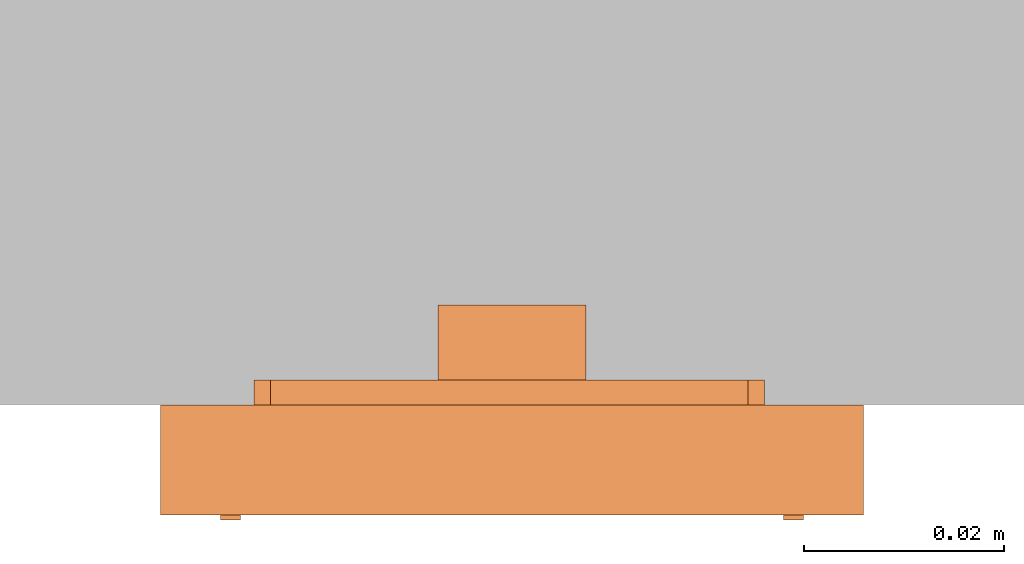
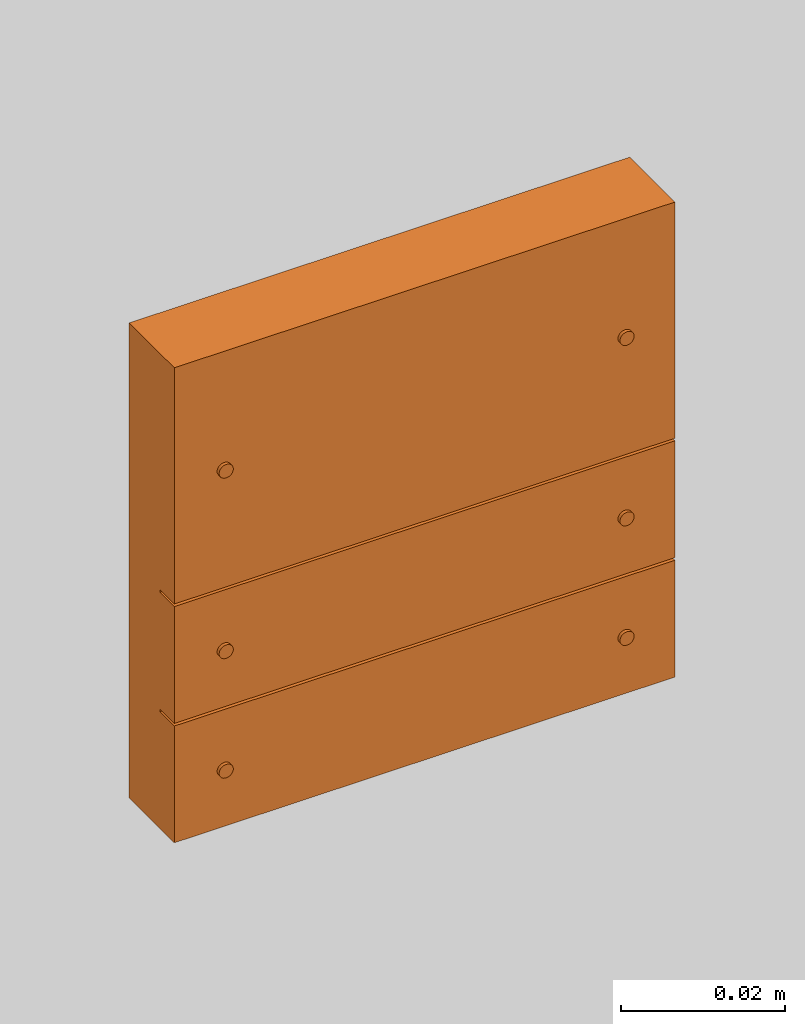
# One storey, part 2 of 2: 1 proxy.
"""IFC2X3 building model written with IfcOpenShell, lengths in metres."""

from ifc_helpers import new_model, entity, si_unit, converted_unit, derived_unit, direction, frame, frame_2d, origin, origin_2d_with_axis, place, context, subcontext, project, spatial, polyline, circle_curve, parameter, trimmed, segment, composite_curve, rectangle, circle, outline, extrude, source, transform, mapped, type_object, type_shapes, element, save


model = new_model("IFC2X3")

# Units and contexts
model_context = context("Model", 3, precision=1e-05, world=origin(), true_north=direction((6.12303176911189e-17, 1.0)))
body_context = subcontext(model_context, "Body", "Model", "MODEL_VIEW")
ifc_project = project(units=[si_unit("LENGTHUNIT", "METRE"), si_unit("AREAUNIT", "SQUARE_METRE"), si_unit("VOLUMEUNIT", "CUBIC_METRE"), converted_unit("PLANEANGLEUNIT", "DEGREE", entity("IfcRatioMeasure", 0.0174532925199433), si_unit("PLANEANGLEUNIT", "RADIAN"), dimensions=[0, 0, 0, 0, 0, 0, 0]), si_unit("MASSUNIT", "GRAM", prefix="KILO"), si_unit("TIMEUNIT", "SECOND"), si_unit("FREQUENCYUNIT", "HERTZ"), si_unit("THERMODYNAMICTEMPERATUREUNIT", "DEGREE_CELSIUS"), derived_unit("THERMALTRANSMITTANCEUNIT", [(si_unit("MASSUNIT", "GRAM", prefix="KILO"), 1), (si_unit("THERMODYNAMICTEMPERATUREUNIT", "KELVIN"), -1), (si_unit("TIMEUNIT", "SECOND"), -3)]), derived_unit("VOLUMETRICFLOWRATEUNIT", [(si_unit("LENGTHUNIT", "METRE"), 3), (si_unit("TIMEUNIT", "SECOND"), -1)]), si_unit("ELECTRICCURRENTUNIT", "AMPERE"), si_unit("ELECTRICVOLTAGEUNIT", "VOLT"), si_unit("POWERUNIT", "WATT"), si_unit("FORCEUNIT", "NEWTON", prefix="KILO"), si_unit("ILLUMINANCEUNIT", "LUX"), si_unit("LUMINOUSFLUXUNIT", "LUMEN"), si_unit("LUMINOUSINTENSITYUNIT", "CANDELA"), derived_unit("USERDEFINED", [(si_unit("MASSUNIT", "GRAM", prefix="KILO"), -1), (si_unit("LENGTHUNIT", "METRE"), -2), (si_unit("TIMEUNIT", "SECOND"), 3), (si_unit("LUMINOUSFLUXUNIT", "LUMEN"), 1)]), derived_unit("LINEARVELOCITYUNIT", [(si_unit("LENGTHUNIT", "METRE"), 1), (si_unit("TIMEUNIT", "SECOND"), -1)]), si_unit("PRESSUREUNIT", "PASCAL"), derived_unit("USERDEFINED", [(si_unit("LENGTHUNIT", "METRE"), -2), (si_unit("MASSUNIT", "GRAM", prefix="KILO"), 1), (si_unit("TIMEUNIT", "SECOND"), -2)])], contexts=[model_context])

# Site, building, storey
site_placement = place(None, origin())
site = spatial("IfcSite", under=ifc_project, at=site_placement, CompositionType="ELEMENT")
building_placement = place(site_placement, origin())
building = spatial("IfcBuilding", under=site, at=building_placement, CompositionType="ELEMENT")
storey_placement = place(building_placement, origin())
storey = spatial("IfcBuildingStorey", under=building, at=storey_placement, Name="Ebene 0", CompositionType="ELEMENT", Elevation=0.0)

# Proxy
building_element_proxy_type = type_object("IfcBuildingElementProxyType", Name="KNX 3 Plus 2f", PredefinedType="NOTDEFINED")
shared_shape = source(origin(), body_context, "Body", "SweptSolid", [
    extrude(circle(Radius=0.001, at=frame_2d((0.0, -4.22994972382185e-18), x_axis=(1.0, 0.0))), frame((0.0281503279999937, -0.0267710735000254, 0.0109999999999981), z_axis=(0.0, 0.0, 1.0), x_axis=(-1.0, 0.0, 0.0)), (0.0, 0.0, 1.0), 0.000500000000000028),
    extrude(circle(Radius=0.001, at=frame_2d((0.0, -4.22994972382185e-18), x_axis=(1.0, 0.0))), frame((-0.0281503279999813, -0.0267710735000254, 0.0109999999999981)), (0.0, 0.0, 1.0), 0.000500000000000028),
    extrude(circle(Radius=0.001, at=frame_2d((0.0, -2.11497486191092e-18), x_axis=(1.0, 0.0))), frame((0.0281503279999938, -0.00902937150002535, 0.0109999999999981), z_axis=(0.0, 0.0, 1.0), x_axis=(-1.0, 0.0, 0.0)), (0.0, 0.0, 1.0), 0.000500000000000028),
    extrude(circle(Radius=0.001, at=frame_2d((0.0, -2.11497486191092e-18), x_axis=(1.0, 0.0))), frame((-0.0281503279999813, -0.00902937150002534, 0.0109999999999981)), (0.0, 0.0, 1.0), 0.000500000000000028),
    extrude(circle(Radius=0.001, at=frame_2d((0.0, -2.11497486191092e-18), x_axis=(1.0, 0.0))), frame((0.0281503279999938, 0.0177710734999747, 0.0109999999999981), z_axis=(0.0, 0.0, 1.0), x_axis=(-1.0, 0.0, 0.0)), (0.0, 0.0, 1.0), 0.000500000000000028),
    extrude(circle(Radius=0.001, at=frame_2d((0.0, -2.11497486191092e-18), x_axis=(1.0, 0.0))), frame((-0.0281503279999812, 0.0177710734999747, 0.0109999999999981)), (0.0, 0.0, 1.0), 0.000500000000000028),
    extrude(outline(polyline([(-0.00737665776090717, -0.00321845649999999), (0.00738192423909283, -0.00321845649999999), (0.00738192423909283, 0.00284013749999998), (0.00654480379664712, 0.00284013749999999), (0.00654480379664711, -0.00245988050000001), (-0.00655007027483279, -0.00245988050000001), (-0.00655007027483277, 0.00283819950000001), (-0.00737665776090717, 0.00283819950000001), (-0.00737665776090717, -0.00321845649999999)])), frame((2.63323911162365e-06, -0.0184309360000254, -0.0100000000000019), z_axis=(0.0, 0.0, 1.0), x_axis=(-1.0, 0.0, 0.0)), (0.0, 0.0, 1.0), 0.0075),
    extrude(outline(composite_curve([segment(polyline([(0.000467124920745127, -0.0238772156111111), (0.0193443469207452, -0.0238772156111111)]), True, "CONTINUOUS"), segment(trimmed(circle_curve(frame_2d((0.0193443469207451, -0.0188772156111111), x_axis=(-1.0, 0.0)), 0.005), [parameter(90.0000000000001)], [parameter(180.0)], True, "PARAMETER"), True, "CONTINUOUS"), segment(polyline([(0.0243443469207451, -0.0188772156111111), (0.0243443469207451, -0.00697722161111111)]), True, "CONTINUOUS"), segment(polyline([(0.0243443469207451, -0.00697722161111111), (0.0259943469207451, -0.00697722161111111)]), True, "CONTINUOUS"), segment(polyline([(0.0259943469207451, -0.00697722161111111), (0.0259943469207451, 0.00697722338888888)]), True, "CONTINUOUS"), segment(polyline([(0.0259943469207451, 0.00697722338888888), (0.0243443469207451, 0.00697722338888888)]), True, "CONTINUOUS"), segment(polyline([(0.0243443469207451, 0.00697722338888888), (0.0243443469207451, 0.0188772173888889)]), True, "CONTINUOUS"), segment(trimmed(circle_curve(frame_2d((0.0193443469207451, 0.0188772173888889), x_axis=(-1.0, 0.0)), 0.005), [parameter(180.0)], [parameter(269.999999999999)], True, "PARAMETER"), True, "CONTINUOUS"), segment(polyline([(0.0193443469207451, 0.0238772173888889), (-0.00794112365266727, 0.0238772173888889)]), True, "CONTINUOUS"), segment(polyline([(-0.00794112365266727, 0.0238772173888889), (-0.0184100970792549, 0.0238772173888889)]), True, "CONTINUOUS"), segment(trimmed(circle_curve(frame_2d((-0.0184100970792549, 0.0188772173888889), x_axis=(-1.0, 0.0)), 0.005), [parameter(269.999999999999)], [parameter(360.0)], True, "PARAMETER"), True, "CONTINUOUS"), segment(polyline([(-0.0234100970792549, 0.0188772173888889), (-0.0234100970792549, 0.00697722338888889)]), True, "CONTINUOUS"), segment(polyline([(-0.0234100970792549, 0.00697722338888889), (-0.0250600970792549, 0.00697722338888889)]), True, "CONTINUOUS"), segment(polyline([(-0.0250600970792549, 0.00697722338888889), (-0.0250600970792549, -0.0069772216111111)]), True, "CONTINUOUS"), segment(polyline([(-0.0250600970792549, -0.0069772216111111), (-0.0234100970792549, -0.0069772216111111)]), True, "CONTINUOUS"), segment(polyline([(-0.0234100970792549, -0.0069772216111111), (-0.0234100970792549, -0.0188772236111111)]), True, "CONTINUOUS"), segment(trimmed(circle_curve(frame_2d((-0.0184100970792549, -0.0188772236111111), x_axis=(-1.0, 0.0)), 0.005), [parameter(0.0)], [parameter(90.0000000000001)], True, "PARAMETER"), True, "CONTINUOUS"), segment(polyline([(-0.0184100970792549, -0.0238772236111111), (0.000467124920745131, -0.0238772236111111)]), True, "CONTINUOUS")], self_intersect=False)), frame((0.000176586434071594, 0.000271078388863558, -0.00250000000000187), z_axis=(0.0, 0.0, 1.0), x_axis=(-1.0, 0.0, 0.0)), (0.0, 0.0, 1.0), 0.0025),
    extrude(rectangle(XDim=0.070301005, YDim=0.017347165, at=origin_2d_with_axis()), frame((0.0, -0.00885578900002534, 0.0074999999999981), z_axis=(0.0, 0.0, 1.0), x_axis=(-1.0, 0.0, 0.0)), (0.0, 0.0, 1.0), 0.0035),
    extrude(rectangle(XDim=0.070300656, YDim=0.035073517, at=origin_2d_with_axis()), frame((0.0, 0.0177343149999747, 0.0074999999999981), z_axis=(0.0, 0.0, 1.0), x_axis=(-1.0, 0.0, 0.0)), (0.0, 0.0, 1.0), 0.0035),
    extrude(rectangle(XDim=0.070301005, YDim=0.017347165, at=origin_2d_with_axis()), frame((0.0, -0.0265974910000254, 0.0074999999999981), z_axis=(0.0, 0.0, 1.0), x_axis=(-1.0, 0.0, 0.0)), (0.0, 0.0, 1.0), 0.0035),
    extrude(rectangle(XDim=0.0705421469999999, YDim=0.070300656, at=frame_2d((-3.46944695195361e-18, 0.0), x_axis=(1.0, 0.0))), frame((0.0, 0.0, 0.0), z_axis=(0.0, 0.0, 1.0), x_axis=(0.0, -1.0, 0.0)), (0.0, 0.0, 1.0), 0.00749999999999997),
    extrude(rectangle(XDim=0.0130948740714799, YDim=0.00530001800000004, at=frame_2d((-8.67361737988404e-19, -9.54097911787244e-18), x_axis=(1.0, 0.0))), frame((5.26647820445838e-06, -0.0186210645000254, -0.00350000000000187), z_axis=(0.0, 0.0, 1.0), x_axis=(-1.0, 0.0, 0.0)), (0.0, 0.0, 1.0), 0.001),
])
type_shapes(building_element_proxy_type, [shared_shape])
proxy_placement = place(storey_placement, frame((-7.2192018927039, -2.38240134987377, 1.53709958372417), z_axis=(0.0, -1.0, 0.0), x_axis=(1.0, 0.0, 0.0)))
element("IfcBuildingElementProxy", 1, at=proxy_placement, inside=storey, type_object=building_element_proxy_type, Name="3 Plus 2f", ObjectType="KNX 3 Plus 2f", context=body_context, shape_type="MappedRepresentation", body=[
    mapped(shared_shape, transform((0.0, 0.0, 0.0), scale=1.0)),
])

save(model, "model.ifc")
